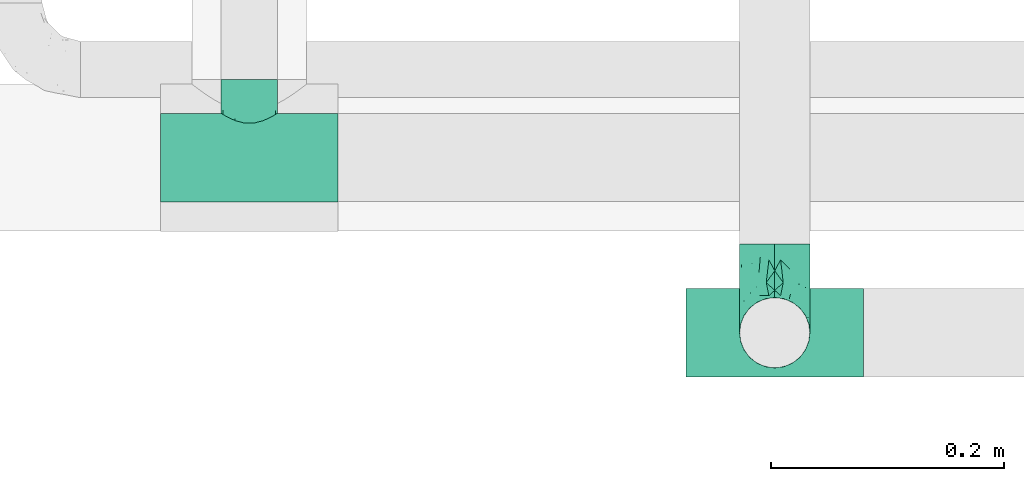
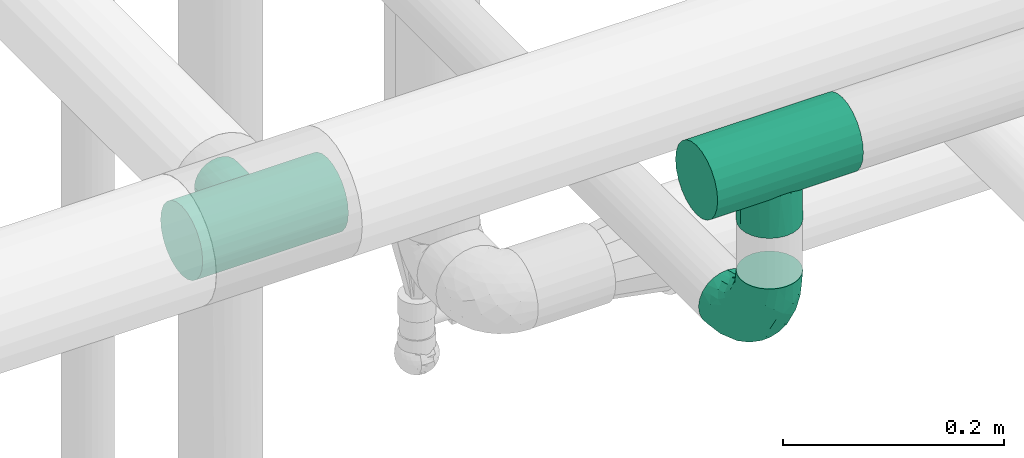
# One storey, part 688 of 827: 3 flow fittings.
"""IFC2X3 building model written with IfcOpenShell, lengths in millimetres."""

from ifc_helpers import new_model, entity, si_unit, converted_unit, derived_unit, direction, frame, origin, place, context, subcontext, project, spatial, faceted_brep, source, transform, mapped, material, type_object, type_shapes, element, save


model = new_model("IFC2X3")

# Units and contexts
model_context = context("Model", 3, precision=0.01, world=origin(), true_north=direction((6.12303176911189e-17, 1.0)))
body_context = subcontext(model_context, "Body", "Model", "MODEL_VIEW")
ifc_project = project(units=[si_unit("LENGTHUNIT", "METRE", prefix="MILLI"), si_unit("AREAUNIT", "SQUARE_METRE"), si_unit("VOLUMEUNIT", "CUBIC_METRE"), converted_unit("PLANEANGLEUNIT", "DEGREE", entity("IfcRatioMeasure", 0.0174532925199433), si_unit("PLANEANGLEUNIT", "RADIAN"), dimensions=[0, 0, 0, 0, 0, 0, 0]), si_unit("MASSUNIT", "GRAM", prefix="KILO"), derived_unit("MASSDENSITYUNIT", [(si_unit("MASSUNIT", "GRAM", prefix="KILO"), 1), (si_unit("LENGTHUNIT", "METRE"), -3)]), derived_unit("MOMENTOFINERTIAUNIT", [(si_unit("LENGTHUNIT", "METRE"), 4)]), si_unit("TIMEUNIT", "SECOND"), si_unit("FREQUENCYUNIT", "HERTZ"), si_unit("THERMODYNAMICTEMPERATUREUNIT", "DEGREE_CELSIUS"), derived_unit("THERMALTRANSMITTANCEUNIT", [(si_unit("MASSUNIT", "GRAM", prefix="KILO"), 1), (si_unit("THERMODYNAMICTEMPERATUREUNIT", "KELVIN"), -1), (si_unit("TIMEUNIT", "SECOND"), -3)]), derived_unit("VOLUMETRICFLOWRATEUNIT", [(si_unit("LENGTHUNIT", "METRE"), 3), (si_unit("TIMEUNIT", "SECOND"), -1)]), derived_unit("MASSFLOWRATEUNIT", [(si_unit("MASSUNIT", "GRAM", prefix="KILO"), 1), (si_unit("TIMEUNIT", "SECOND"), -1)]), derived_unit("ROTATIONALFREQUENCYUNIT", [(si_unit("TIMEUNIT", "SECOND"), -1)]), si_unit("ELECTRICCURRENTUNIT", "AMPERE"), si_unit("ELECTRICVOLTAGEUNIT", "VOLT"), si_unit("POWERUNIT", "WATT"), si_unit("FORCEUNIT", "NEWTON", prefix="KILO"), si_unit("ILLUMINANCEUNIT", "LUX"), si_unit("LUMINOUSFLUXUNIT", "LUMEN"), si_unit("LUMINOUSINTENSITYUNIT", "CANDELA"), derived_unit("USERDEFINED", [(si_unit("MASSUNIT", "GRAM", prefix="KILO"), -1), (si_unit("LENGTHUNIT", "METRE"), -2), (si_unit("TIMEUNIT", "SECOND"), 3), (si_unit("LUMINOUSFLUXUNIT", "LUMEN"), 1)]), derived_unit("LINEARVELOCITYUNIT", [(si_unit("LENGTHUNIT", "METRE"), 1), (si_unit("TIMEUNIT", "SECOND"), -1)]), si_unit("PRESSUREUNIT", "PASCAL"), derived_unit("USERDEFINED", [(si_unit("LENGTHUNIT", "METRE"), -2), (si_unit("MASSUNIT", "GRAM", prefix="KILO"), 1), (si_unit("TIMEUNIT", "SECOND"), -2)]), derived_unit("LINEARFORCEUNIT", [(si_unit("MASSUNIT", "GRAM", prefix="KILO"), 1), (si_unit("LENGTHUNIT", "METRE"), 1), (si_unit("TIMEUNIT", "SECOND"), -2), (si_unit("LENGTHUNIT", "METRE"), -1)]), derived_unit("PLANARFORCEUNIT", [(si_unit("MASSUNIT", "GRAM", prefix="KILO"), 1), (si_unit("LENGTHUNIT", "METRE"), 1), (si_unit("TIMEUNIT", "SECOND"), -2), (si_unit("LENGTHUNIT", "METRE"), -2)])], contexts=[model_context])

# Site, building, storey
site_placement = place(None, origin())
site = spatial("IfcSite", under=ifc_project, at=site_placement, CompositionType="ELEMENT")
building_placement = place(site_placement, origin())
building = spatial("IfcBuilding", under=site, at=building_placement, CompositionType="ELEMENT")
storey_placement = place(building_placement, frame((0.0, 0.0, 28200.0)))
storey = spatial("IfcBuildingStorey", under=building, at=storey_placement, Name="08", CompositionType="ELEMENT", Elevation=28200.0)

# Flow fittings
ifc_material = material()
pipe_fitting_type_1 = type_object("IfcPipeFittingType", Name="ADSK_1", PredefinedType="NOTDEFINED", material=ifc_material)
shared_shape_1 = source(origin(), body_context, "Body", "Brep", [
    faceted_brep([(-76.0, 9.85, -36.75), (-76.0, 0.0, -38.05), (-76.0, -9.85, -36.75), (-76.0, -19.03, -32.95), (-76.0, -26.91, -26.91), (-76.0, -32.95, -19.03), (-76.0, -36.75, -9.85), (-76.0, -38.05, 0.0), (-76.0, -36.75, 9.85), (-76.0, -32.95, 19.02), (-76.0, -26.91, 26.91), (-76.0, -19.03, 32.95), (-76.0, -9.85, 36.75), (-76.0, 0.0, 38.05), (-76.0, 9.85, 36.75), (-76.0, 19.02, 32.95), (-76.0, 26.91, 26.91), (-76.0, 32.95, 19.02), (-76.0, 36.75, 9.85), (-76.0, 38.05, 0.0), (-76.0, 36.75, -9.85), (-76.0, 32.95, -19.03), (-76.0, 26.91, -26.91), (-76.0, 19.02, -32.95), (76.0, 26.91, -26.91), (76.0, 32.95, -19.03), (76.0, 36.75, -9.85), (76.0, 38.05, 0.0), (76.0, 36.75, 9.85), (76.0, 32.95, 19.02), (76.0, 26.91, 26.91), (76.0, 19.02, 32.95), (76.0, 9.85, 36.75), (76.0, 0.0, 38.05), (76.0, -9.85, 36.75), (76.0, -19.03, 32.95), (76.0, -26.91, 26.91), (76.0, -32.95, 19.02), (76.0, -36.75, 9.85), (76.0, -38.05, 0.0), (76.0, -36.75, -9.85), (76.0, -32.95, -19.03), (76.0, -26.91, -26.91), (76.0, -19.03, -32.95), (76.0, -9.85, -36.75), (76.0, 0.0, -38.05), (76.0, 9.85, -36.75), (76.0, 19.02, -32.95), (22.62, -37.1, 8.45), (23.39, -37.58, 4.22), (24.15, -38.05, 0.0), (18.42, -34.7, 15.61), (4.31, -29.72, 23.76), (12.18, -31.83, 20.86), (8.24, -30.77, 22.31), (-24.15, -38.05, 0.0), (-23.39, -37.58, 4.22), (-22.63, -37.1, 8.44), (-18.43, -34.7, 15.61), (-12.18, -31.83, 20.85), (-4.31, -29.72, 23.76), (0.0, -29.72, 23.76), (4.31, -29.72, -23.76), (12.18, -31.83, -20.86), (8.24, -30.77, -22.31), (18.42, -34.7, -15.61), (22.62, -37.1, -8.45), (23.39, -37.58, -4.22), (-4.31, -29.72, -23.76), (-12.18, -31.83, -20.85), (-18.43, -34.7, -15.61), (0.0, -29.72, -23.76), (-22.63, -37.1, -8.44), (-23.39, -37.58, -4.22), (0.0, -67.0, -24.15), (6.25, -67.0, -23.33), (12.08, -67.0, -20.91), (17.08, -67.0, -17.08), (20.91, -67.0, -12.08), (23.33, -67.0, -6.25), (24.15, -67.0, 0.0), (23.33, -67.0, 6.25), (20.91, -67.0, 12.07), (17.08, -67.0, 17.08), (12.08, -67.0, 20.91), (6.25, -67.0, 23.33), (0.0, -67.0, 24.15), (-6.25, -67.0, 23.33), (-12.07, -67.0, 20.91), (-17.08, -67.0, 17.08), (-20.91, -67.0, 12.07), (-23.33, -67.0, 6.25), (-24.15, -67.0, 0.0), (-23.33, -67.0, -6.25), (-20.91, -67.0, -12.08), (-17.08, -67.0, -17.08), (-12.07, -67.0, -20.91), (-6.25, -67.0, -23.33)], [[[0, 1, 2, 3, 4, 5, 6, 7, 8, 9, 10, 11, 12, 13, 14, 15, 16, 17, 18, 19, 20, 21, 22, 23]], [[24, 25, 26, 27, 28, 29, 30, 31, 32, 33, 34, 35, 36, 37, 38, 39, 40, 41, 42, 43, 44, 45, 46, 47]], [[39, 38, 48]], [[39, 48, 49, 50]], [[38, 51, 48]], [[37, 36, 52]], [[53, 51, 37]], [[37, 52, 54, 53]], [[36, 10, 52]], [[37, 51, 38]], [[7, 55, 56, 57]], [[8, 7, 57]], [[57, 58, 8]], [[59, 60, 9]], [[59, 9, 58]], [[9, 60, 10]], [[58, 9, 8]], [[10, 60, 61, 52]], [[36, 35, 11, 10]], [[13, 12, 34, 33]], [[12, 11, 35, 34]], [[14, 13, 33, 32]], [[29, 28, 18, 17]], [[16, 15, 31, 30]], [[17, 16, 30, 29]], [[32, 31, 15, 14]], [[19, 18, 28, 27]], [[26, 25, 21, 20]], [[25, 24, 22, 21]], [[27, 26, 20, 19]], [[45, 44, 2, 1]], [[0, 23, 47, 46]], [[1, 0, 46, 45]], [[24, 47, 23, 22]], [[3, 2, 44, 43]], [[43, 42, 4, 3]], [[42, 41, 62]], [[41, 63, 64, 62]], [[41, 65, 63]], [[42, 62, 4]], [[40, 39, 66]], [[66, 65, 40]], [[39, 50, 67, 66]], [[40, 65, 41]], [[68, 69, 5]], [[5, 4, 68]], [[69, 70, 5]], [[4, 62, 71, 68]], [[70, 72, 6]], [[72, 7, 6]], [[7, 72, 73, 55]], [[70, 6, 5]], [[74, 75, 76, 77, 78, 79, 80, 81, 82, 83, 84, 85, 86, 87, 88, 89, 90, 91, 92, 93, 94, 95, 96, 97]], [[56, 92, 91]], [[86, 60, 87]], [[59, 89, 88]], [[84, 54, 85]], [[49, 80, 50]], [[59, 88, 87]], [[49, 48, 81]], [[91, 57, 56]], [[55, 92, 56]], [[57, 91, 90]], [[57, 90, 58]], [[89, 58, 90]], [[89, 59, 58]], [[87, 60, 59]], [[86, 52, 61, 60]], [[84, 53, 54]], [[83, 53, 84]], [[48, 82, 81]], [[83, 82, 51]], [[52, 86, 85]], [[54, 52, 85]], [[53, 83, 51]], [[51, 82, 48]], [[80, 49, 81]], [[79, 67, 80]], [[77, 65, 78]], [[64, 76, 75]], [[79, 66, 67]], [[78, 66, 79]], [[63, 77, 76]], [[67, 50, 80]], [[66, 78, 65]], [[75, 62, 64]], [[63, 65, 77]], [[74, 68, 71, 62]], [[74, 62, 75]], [[73, 92, 55]], [[69, 97, 96]], [[73, 72, 93]], [[95, 69, 96]], [[72, 94, 93]], [[95, 94, 70]], [[68, 74, 97]], [[97, 69, 68]], [[69, 95, 70]], [[70, 94, 72]], [[92, 73, 93]], [[64, 63, 76]]]),
])
type_shapes(pipe_fitting_type_1, [shared_shape_1])
flow_fitting_1_placement = place(storey_placement, frame((53121.06, 16072.38, 2700.04), z_axis=(0.0, 0.0, 1.0), x_axis=(-1.0, 0.0, 0.0)))
element("IfcFlowFitting", 1, at=flow_fitting_1_placement, inside=storey, type_object=pipe_fitting_type_1, material=ifc_material, Name="ADSK_1", ObjectType="ADSK_1", context=body_context, shape_type="MappedRepresentation", body=[
    mapped(shared_shape_1, transform((0.0, 0.0, 0.0), scale=1.0)),
])
pipe_fitting_type_2 = type_object("IfcPipeFittingType", Name="ADSK_1", PredefinedType="NOTDEFINED", material=ifc_material)
shared_shape_2 = source(origin(), body_context, "Body", "Brep", [
    faceted_brep([(-76.0, 15.07, -26.11), (-76.0, 7.8, -29.12), (-76.0, 0.0, -30.15), (-76.0, -7.8, -29.12), (-76.0, -15.08, -26.11), (-76.0, -21.32, -21.32), (-76.0, -26.11, -15.08), (-76.0, -29.12, -7.8), (-76.0, -30.15, 0.0), (-76.0, -29.12, 7.8), (-76.0, -26.11, 15.07), (-76.0, -21.32, 21.32), (-76.0, -15.08, 26.11), (-76.0, -7.8, 29.12), (-76.0, 0.0, 30.15), (-76.0, 7.8, 29.12), (-76.0, 15.07, 26.11), (-76.0, 21.32, 21.32), (-76.0, 26.11, 15.07), (-76.0, 29.12, 7.8), (-76.0, 30.15, 0.0), (-76.0, 29.12, -7.8), (-76.0, 26.11, -15.08), (-76.0, 21.32, -21.32), (0.0, 76.0, -30.15), (-7.8, 76.0, -29.12), (-15.07, 76.0, -26.11), (-21.32, 76.0, -21.32), (-26.11, 76.0, -15.08), (-29.12, 76.0, -7.8), (-30.15, 76.0, 0.0), (-29.12, 76.0, 7.8), (-26.11, 76.0, 15.07), (-21.32, 76.0, 21.32), (-15.07, 76.0, 26.11), (-7.8, 76.0, 29.12), (0.0, 76.0, 30.15), (7.8, 76.0, 29.12), (15.08, 76.0, 26.11), (21.32, 76.0, 21.32), (26.11, 76.0, 15.07), (29.12, 76.0, 7.8), (30.15, 76.0, 0.0), (29.12, 76.0, -7.8), (26.11, 76.0, -15.08), (21.32, 76.0, -21.32), (15.08, 76.0, -26.11), (7.8, 76.0, -29.12), (10.79, 31.43, 21.07), (4.32, 31.7, 25.72), (1.65, 15.19, 19.92), (-61.17, -27.8, 0.0), (-51.1, -25.49, 9.84), (-56.14, -10.61, 27.27), (-31.7, -4.32, 25.72), (-39.75, 1.72, 29.41), (-43.2, -24.95, 0.0), (-1.86, 1.86, 0.0), (4.49, 7.65, 5.78), (-7.82, -4.61, 5.83), (-56.21, -22.79, 17.21), (-58.98, -3.38, 29.7), (-53.96, 5.6, 30.07), (-10.86, 10.86, 25.48), (-17.2, -2.6, 20.44), (-49.15, -16.01, 22.7), (-22.18, -14.24, 7.99), (-28.4, -17.42, 0.0), (-13.61, -9.88, 0.0), (-39.0, 23.48, 27.76), (-58.76, 12.54, 28.36), (-41.61, 15.41, 29.48), (16.01, 49.15, 22.7), (-58.55, 25.93, 19.53), (-51.53, 33.5, 13.51), (-64.92, 28.76, 12.4), (-7.48, 23.14, 28.25), (-1.72, 39.75, 29.41), (-12.04, 27.88, 29.88), (-63.91, 18.81, 24.52), (-11.63, 65.16, 28.18), (-4.97, 57.02, 30.05), (9.88, 13.61, 0.0), (-62.5, 31.74, 5.02), (-45.17, 30.98, 21.2), (-21.78, 9.76, 28.58), (10.61, 56.14, 27.27), (-32.09, 54.42, 13.26), (22.79, 56.21, 17.21), (15.38, 31.17, 15.63), (25.49, 51.1, 9.84), (21.84, 36.35, 5.92), (24.95, 43.2, 0.0), (3.38, 58.98, 29.7), (-31.17, -15.38, 15.63), (-39.39, 41.78, 15.45), (-34.56, 41.13, 20.79), (-39.81, -23.25, 5.49), (27.8, 61.17, 0.0), (-31.74, 62.5, 5.02), (-53.07, 36.29, 0.0), (-42.95, 42.95, 7.29), (-36.29, 53.07, 0.0), (-19.83, 58.51, 24.79), (-25.48, 60.2, 19.41), (-14.53, 50.96, 28.57), (-13.31, 37.09, 30.07), (-26.16, 40.06, 26.4), (-32.43, -10.35, 21.9), (17.42, 28.4, 0.0), (14.24, 22.18, 7.99), (-38.67, 9.72, 30.15), (-24.66, 17.36, 30.09), (-37.08, 31.49, 24.99), (-49.27, 22.83, 25.24), (-20.8, 38.81, 28.63), (-27.58, 27.58, 29.2), (-36.07, -20.23, 10.71), (-15.19, -6.16, 14.9), (6.6, 15.4, 14.49), (-2.51, 2.51, 11.35), (-65.16, 11.63, -28.18), (-49.15, -16.01, -22.7), (-57.02, 4.97, -30.05), (-25.93, 58.55, -19.53), (-33.5, 51.53, -13.51), (-28.76, 64.92, -12.4), (-60.2, 25.48, -19.41), (-58.51, 19.83, -24.79), (4.61, 7.82, -5.83), (-7.65, -4.49, -5.78), (-2.51, 2.51, -11.35), (-62.5, 31.74, -5.02), (-50.96, 14.53, -28.57), (-37.09, 13.31, -30.07), (-42.95, 42.95, -7.29), (25.49, 51.1, -9.84), (22.79, 56.21, -17.21), (-40.06, 26.16, -26.4), (3.38, 58.98, -29.7), (-5.6, 53.96, -30.07), (-27.88, 12.04, -29.88), (-9.76, 21.78, -28.58), (-23.14, 7.48, -28.25), (-51.1, -25.49, -9.84), (15.38, 31.17, -15.63), (16.01, 49.15, -22.7), (-23.48, 39.0, -27.76), (-12.54, 58.76, -28.36), (-15.41, 41.61, -29.48), (-56.21, -22.79, -17.21), (-9.72, 38.67, -30.15), (-17.36, 24.66, -30.09), (-22.18, -14.24, -7.99), (-41.13, 34.56, -20.79), (-31.74, 62.5, -5.02), (-58.98, -3.38, -29.7), (-31.17, -15.38, -15.63), (-56.14, -10.61, -27.27), (14.24, 22.18, -7.99), (23.25, 39.81, -5.49), (-31.49, 37.08, -24.99), (-15.19, -6.16, -14.9), (1.65, 15.19, -19.92), (-18.81, 63.91, -24.52), (-32.59, -11.62, -20.84), (-31.7, -4.32, -25.72), (-17.2, -2.6, -20.44), (-39.75, 1.72, -29.41), (-54.42, 32.09, -13.26), (-30.98, 45.17, -21.2), (10.61, 56.14, -27.27), (10.23, 31.31, -21.52), (4.32, 31.7, -25.72), (-41.78, 39.39, -15.45), (-1.72, 39.75, -29.41), (-36.35, -21.84, -5.92), (-22.83, 49.27, -25.24), (-38.81, 20.8, -28.63), (-27.58, 27.58, -29.2), (-10.86, 10.86, -25.48), (20.23, 36.07, -10.71), (6.6, 15.4, -14.49)], [[[0, 1, 2, 3, 4, 5, 6, 7, 8, 9, 10, 11, 12, 13, 14, 15, 16, 17, 18, 19, 20, 21, 22, 23]], [[24, 25, 26, 27, 28, 29, 30, 31, 32, 33, 34, 35, 36, 37, 38, 39, 40, 41, 42, 43, 44, 45, 46, 47]], [[48, 49, 50]], [[51, 52, 9]], [[53, 54, 55]], [[9, 52, 10]], [[56, 52, 51]], [[57, 58, 59]], [[11, 10, 60]], [[14, 61, 62]], [[63, 54, 64]], [[65, 12, 11]], [[65, 53, 12]], [[66, 67, 68]], [[69, 70, 71]], [[72, 39, 38]], [[73, 74, 75]], [[15, 70, 16]], [[76, 77, 78]], [[16, 79, 17]], [[13, 61, 14]], [[35, 80, 81]], [[14, 62, 15]], [[17, 73, 18]], [[57, 82, 58]], [[20, 19, 83]], [[75, 19, 18]], [[70, 15, 62]], [[73, 84, 74]], [[78, 85, 76]], [[38, 86, 72]], [[32, 31, 87]], [[88, 89, 90]], [[91, 92, 90]], [[72, 86, 49]], [[36, 93, 37]], [[75, 83, 19]], [[36, 35, 81]], [[60, 94, 65]], [[40, 90, 41]], [[95, 96, 87]], [[88, 90, 40]], [[66, 97, 67]], [[90, 98, 41]], [[40, 39, 88]], [[99, 31, 30]], [[20, 83, 100]], [[101, 102, 100]], [[52, 60, 10]], [[102, 99, 30]], [[96, 103, 104]], [[83, 101, 100]], [[12, 53, 13]], [[104, 103, 33]], [[105, 106, 81]], [[107, 105, 103]], [[64, 54, 108]], [[80, 103, 105]], [[80, 35, 34]], [[34, 33, 103]], [[86, 38, 37]], [[109, 110, 82]], [[71, 111, 112]], [[69, 107, 113]], [[79, 73, 17]], [[114, 113, 84]], [[33, 32, 104]], [[115, 107, 116]], [[105, 115, 106]], [[93, 81, 77]], [[54, 53, 65]], [[61, 53, 55]], [[108, 94, 64]], [[54, 63, 85]], [[93, 86, 37]], [[77, 76, 49]], [[77, 49, 86]], [[49, 63, 50]], [[60, 52, 117]], [[65, 11, 60]], [[39, 72, 88]], [[89, 88, 72]], [[71, 70, 62]], [[79, 70, 114]], [[103, 96, 107]], [[69, 113, 114]], [[112, 106, 116]], [[77, 81, 106]], [[112, 116, 71]], [[112, 55, 85]], [[64, 50, 63]], [[57, 59, 68]], [[32, 87, 104]], [[96, 104, 87]], [[94, 118, 64]], [[50, 119, 89]], [[50, 64, 118]], [[50, 89, 48]], [[81, 93, 36]], [[86, 93, 77]], [[53, 61, 13]], [[62, 61, 55]], [[71, 62, 111]], [[69, 71, 116]], [[95, 101, 74]], [[99, 101, 87]], [[118, 66, 59]], [[117, 97, 66]], [[117, 66, 94]], [[91, 89, 110]], [[91, 110, 109]], [[110, 89, 119]], [[9, 8, 51]], [[98, 90, 92]], [[98, 42, 41]], [[101, 83, 74]], [[101, 99, 102]], [[87, 31, 99]], [[62, 55, 111]], [[55, 112, 111]], [[107, 69, 116]], [[70, 69, 114]], [[107, 96, 113]], [[84, 113, 96]], [[84, 96, 95]], [[114, 84, 73]], [[70, 79, 16]], [[73, 79, 114]], [[54, 85, 55]], [[76, 85, 63]], [[49, 76, 63]], [[77, 106, 78]], [[106, 112, 78]], [[85, 78, 112]], [[73, 75, 18]], [[83, 75, 74]], [[103, 80, 34]], [[81, 80, 105]], [[101, 95, 87]], [[84, 95, 74]], [[106, 115, 116]], [[105, 107, 115]], [[120, 59, 58]], [[82, 110, 58]], [[119, 58, 110]], [[118, 59, 120]], [[66, 68, 59]], [[54, 65, 108]], [[94, 108, 65]], [[66, 118, 94]], [[50, 118, 120]], [[50, 120, 119]], [[119, 120, 58]], [[89, 72, 48]], [[49, 48, 72]], [[60, 117, 94]], [[117, 52, 97]], [[52, 56, 97]], [[67, 97, 56]], [[92, 91, 109]], [[89, 91, 90]], [[121, 1, 0]], [[122, 5, 4]], [[2, 1, 123]], [[124, 125, 126]], [[127, 128, 23]], [[129, 130, 131]], [[100, 132, 20]], [[133, 134, 123]], [[135, 100, 102]], [[136, 137, 44]], [[133, 128, 138]], [[24, 139, 140]], [[141, 142, 143]], [[121, 128, 133]], [[6, 144, 7]], [[137, 145, 146]], [[144, 51, 7]], [[147, 148, 149]], [[144, 6, 150]], [[149, 151, 152]], [[153, 68, 67]], [[154, 128, 127]], [[30, 155, 102]], [[43, 42, 98]], [[156, 3, 2]], [[157, 144, 150]], [[158, 4, 3]], [[24, 140, 25]], [[155, 135, 102]], [[159, 160, 109]], [[30, 29, 155]], [[147, 138, 161]], [[27, 124, 28]], [[57, 129, 82]], [[162, 163, 131]], [[27, 26, 164]], [[148, 26, 25]], [[165, 166, 167]], [[24, 47, 139]], [[143, 168, 141]], [[22, 21, 169]], [[125, 124, 170]], [[148, 25, 140]], [[46, 146, 171]], [[158, 122, 4]], [[0, 23, 128]], [[1, 121, 123]], [[109, 82, 159]], [[45, 44, 137]], [[146, 46, 45]], [[136, 43, 98]], [[132, 21, 20]], [[136, 98, 92]], [[172, 173, 146]], [[46, 171, 47]], [[43, 136, 44]], [[174, 154, 169]], [[171, 173, 175]], [[6, 5, 150]], [[126, 29, 28]], [[176, 56, 144]], [[122, 158, 166]], [[164, 124, 27]], [[177, 161, 170]], [[23, 22, 127]], [[178, 138, 179]], [[133, 178, 134]], [[156, 123, 168]], [[156, 158, 3]], [[168, 143, 166]], [[168, 166, 158]], [[166, 180, 167]], [[173, 171, 146]], [[139, 171, 175]], [[172, 145, 163]], [[173, 180, 142]], [[5, 122, 150]], [[157, 150, 122]], [[137, 136, 181]], [[146, 45, 137]], [[149, 148, 140]], [[164, 148, 177]], [[128, 154, 138]], [[147, 161, 177]], [[152, 134, 179]], [[168, 123, 134]], [[152, 179, 149]], [[152, 175, 142]], [[57, 130, 129]], [[157, 165, 167]], [[22, 169, 127]], [[154, 127, 169]], [[163, 167, 180]], [[162, 157, 167]], [[173, 163, 180]], [[182, 163, 145]], [[123, 156, 2]], [[158, 156, 168]], [[171, 139, 47]], [[140, 139, 175]], [[149, 140, 151]], [[147, 149, 179]], [[174, 135, 125]], [[132, 135, 169]], [[176, 157, 153]], [[176, 153, 67]], [[153, 157, 162]], [[182, 159, 129]], [[181, 160, 159]], [[181, 159, 145]], [[51, 144, 56]], [[51, 8, 7]], [[135, 132, 100]], [[169, 21, 132]], [[126, 155, 29]], [[135, 155, 125]], [[140, 175, 151]], [[175, 152, 151]], [[138, 147, 179]], [[148, 147, 177]], [[138, 154, 161]], [[170, 161, 154]], [[170, 154, 174]], [[177, 170, 124]], [[148, 164, 26]], [[124, 164, 177]], [[173, 142, 175]], [[143, 142, 180]], [[166, 143, 180]], [[168, 134, 141]], [[134, 152, 141]], [[142, 141, 152]], [[124, 126, 28]], [[155, 126, 125]], [[128, 121, 0]], [[123, 121, 133]], [[135, 174, 169]], [[170, 174, 125]], [[134, 178, 179]], [[133, 138, 178]], [[130, 153, 162]], [[68, 153, 130]], [[57, 68, 130]], [[182, 129, 131]], [[159, 82, 129]], [[157, 122, 165]], [[166, 165, 122]], [[163, 162, 167]], [[162, 131, 130]], [[145, 172, 146]], [[163, 173, 172]], [[159, 182, 145]], [[131, 163, 182]], [[56, 176, 67]], [[157, 176, 144]], [[137, 181, 145]], [[181, 136, 160]], [[136, 92, 160]], [[109, 160, 92]]]),
])
type_shapes(pipe_fitting_type_2, [shared_shape_2])
flow_fitting_2_placement = place(storey_placement, frame((53571.41, 15922.38, 2498.17), z_axis=(-1.0, 0.0, 0.0), x_axis=(0.0, -1.0, 0.0)))
element("IfcFlowFitting", 2, at=flow_fitting_2_placement, inside=storey, type_object=pipe_fitting_type_2, material=ifc_material, Name="ADSK_1", ObjectType="ADSK_1", context=body_context, shape_type="MappedRepresentation", body=[
    mapped(shared_shape_2, transform((0.0, 0.0, 0.0), scale=1.0)),
])
pipe_fitting_type_3 = type_object("IfcPipeFittingType", Name="ADSK_1", PredefinedType="NOTDEFINED", material=ifc_material)
shared_shape_3 = source(origin(), body_context, "Body", "Brep", [
    faceted_brep([(-76.0, 9.85, -36.75), (-76.0, 0.0, -38.05), (-76.0, -9.85, -36.75), (-76.0, -19.03, -32.95), (-76.0, -26.91, -26.91), (-76.0, -32.95, -19.03), (-76.0, -36.75, -9.85), (-76.0, -38.05, 0.0), (-76.0, -36.75, 9.85), (-76.0, -32.95, 19.02), (-76.0, -26.91, 26.91), (-76.0, -19.03, 32.95), (-76.0, -9.85, 36.75), (-76.0, 0.0, 38.05), (-76.0, 9.85, 36.75), (-76.0, 19.02, 32.95), (-76.0, 26.91, 26.91), (-76.0, 32.95, 19.02), (-76.0, 36.75, 9.85), (-76.0, 38.05, 0.0), (-76.0, 36.75, -9.85), (-76.0, 32.95, -19.03), (-76.0, 26.91, -26.91), (-76.0, 19.02, -32.95), (76.0, 26.91, -26.91), (76.0, 32.95, -19.03), (76.0, 36.75, -9.85), (76.0, 38.05, 0.0), (76.0, 36.75, 9.85), (76.0, 32.95, 19.02), (76.0, 26.91, 26.91), (76.0, 19.02, 32.95), (76.0, 9.85, 36.75), (76.0, 0.0, 38.05), (76.0, -9.85, 36.75), (76.0, -19.03, 32.95), (76.0, -26.91, 26.91), (76.0, -32.95, 19.02), (76.0, -36.75, 9.85), (76.0, -38.05, 0.0), (76.0, -36.75, -9.85), (76.0, -32.95, -19.03), (76.0, -26.91, -26.91), (76.0, -19.03, -32.95), (76.0, -9.85, -36.75), (76.0, 0.0, -38.05), (76.0, 9.85, -36.75), (76.0, 19.02, -32.95), (30.15, -38.05, 0.0), (-30.15, -38.05, 0.0), (28.17, -36.5, 10.76), (29.16, -37.27, 5.38), (22.87, -32.58, 19.65), (15.21, -27.75, 26.03), (5.49, -23.85, 29.65), (-29.16, -37.27, 5.38), (-28.17, -36.5, 10.75), (-15.21, -27.75, 26.03), (-5.5, -23.85, 29.64), (-22.87, -32.59, 19.65), (0.0, -23.85, 29.65), (5.49, -23.85, -29.65), (22.87, -32.58, -19.65), (15.21, -27.75, -26.03), (28.17, -36.5, -10.76), (29.16, -37.27, -5.38), (-5.5, -23.85, -29.64), (-15.21, -27.75, -26.03), (-22.87, -32.59, -19.65), (-28.17, -36.5, -10.75), (-29.16, -37.27, -5.38), (0.0, -23.85, -29.65), (0.0, -70.0, -30.15), (7.8, -70.0, -29.12), (15.08, -70.0, -26.11), (21.32, -70.0, -21.32), (26.11, -70.0, -15.08), (29.12, -70.0, -7.8), (30.15, -70.0, 0.0), (29.12, -70.0, 7.8), (26.11, -70.0, 15.07), (21.32, -70.0, 21.32), (15.08, -70.0, 26.11), (7.8, -70.0, 29.12), (0.0, -70.0, 30.15), (-7.8, -70.0, 29.12), (-15.07, -70.0, 26.11), (-21.32, -70.0, 21.32), (-26.11, -70.0, 15.07), (-29.12, -70.0, 7.8), (-30.15, -70.0, 0.0), (-29.12, -70.0, -7.8), (-26.11, -70.0, -15.08), (-21.32, -70.0, -21.32), (-15.07, -70.0, -26.11), (-7.8, -70.0, -29.12)], [[[0, 1, 2, 3, 4, 5, 6, 7, 8, 9, 10, 11, 12, 13, 14, 15, 16, 17, 18, 19, 20, 21, 22, 23]], [[24, 25, 26, 27, 28, 29, 30, 31, 32, 33, 34, 35, 36, 37, 38, 39, 40, 41, 42, 43, 44, 45, 46, 47]], [[39, 38, 48]], [[8, 7, 49]], [[38, 50, 51, 48]], [[38, 37, 50]], [[37, 36, 52]], [[53, 52, 36]], [[54, 53, 36]], [[36, 35, 54]], [[37, 52, 50]], [[8, 49, 55, 56]], [[56, 9, 8]], [[57, 58, 10]], [[9, 59, 10]], [[59, 9, 56]], [[10, 59, 57]], [[58, 11, 10]], [[11, 58, 60, 54]], [[13, 12, 34, 33]], [[12, 11, 35, 34]], [[14, 13, 33, 32]], [[29, 28, 18, 17]], [[16, 15, 31, 30]], [[17, 16, 30, 29]], [[32, 31, 15, 14]], [[19, 18, 28, 27]], [[35, 11, 54]], [[26, 25, 21, 20]], [[25, 24, 22, 21]], [[27, 26, 20, 19]], [[45, 44, 2, 1]], [[0, 23, 47, 46]], [[1, 0, 46, 45]], [[24, 47, 23, 22]], [[3, 2, 44, 43]], [[43, 61, 3]], [[42, 62, 63]], [[62, 42, 41]], [[63, 61, 42]], [[42, 61, 43]], [[40, 39, 48]], [[6, 49, 7]], [[40, 64, 41]], [[40, 48, 65, 64]], [[41, 64, 62]], [[66, 67, 4]], [[4, 68, 5]], [[68, 4, 67]], [[66, 4, 3]], [[6, 69, 70, 49]], [[69, 6, 5]], [[69, 5, 68]], [[3, 61, 71, 66]], [[72, 73, 74, 75, 76, 77, 78, 79, 80, 81, 82, 83, 84, 85, 86, 87, 88, 89, 90, 91, 92, 93, 94, 95]], [[51, 78, 48]], [[57, 87, 86]], [[87, 59, 88]], [[57, 86, 85]], [[55, 49, 90]], [[90, 89, 55]], [[89, 88, 56]], [[89, 56, 55]], [[59, 56, 88]], [[87, 57, 59]], [[51, 50, 79]], [[85, 58, 57]], [[84, 54, 60, 58]], [[53, 83, 82]], [[81, 53, 82]], [[50, 80, 79]], [[81, 80, 52]], [[54, 84, 83]], [[83, 53, 54]], [[84, 58, 85]], [[53, 81, 52]], [[52, 80, 50]], [[78, 51, 79]], [[77, 65, 78]], [[72, 61, 73]], [[70, 90, 49]], [[77, 64, 65]], [[77, 76, 64]], [[75, 62, 76]], [[65, 48, 78]], [[64, 76, 62]], [[74, 73, 63]], [[63, 62, 75]], [[63, 73, 61]], [[63, 75, 74]], [[72, 66, 71, 61]], [[67, 95, 94]], [[93, 67, 94]], [[69, 92, 91]], [[93, 92, 68]], [[66, 72, 95]], [[95, 67, 66]], [[67, 93, 68]], [[68, 92, 69]], [[90, 70, 91]], [[70, 69, 91]]]),
])
type_shapes(pipe_fitting_type_3, [shared_shape_3])
flow_fitting_3_placement = place(storey_placement, frame((53571.41, 15922.38, 2700.0), z_axis=(0.0, -1.0, 0.0), x_axis=(1.0, 0.0, 0.0)))
element("IfcFlowFitting", 3, at=flow_fitting_3_placement, inside=storey, type_object=pipe_fitting_type_3, material=ifc_material, Name="ADSK_1", ObjectType="ADSK_1", context=body_context, shape_type="MappedRepresentation", body=[
    mapped(shared_shape_3, transform((0.0, 0.0, 0.0), scale=1.0)),
])

save(model, "model.ifc")
